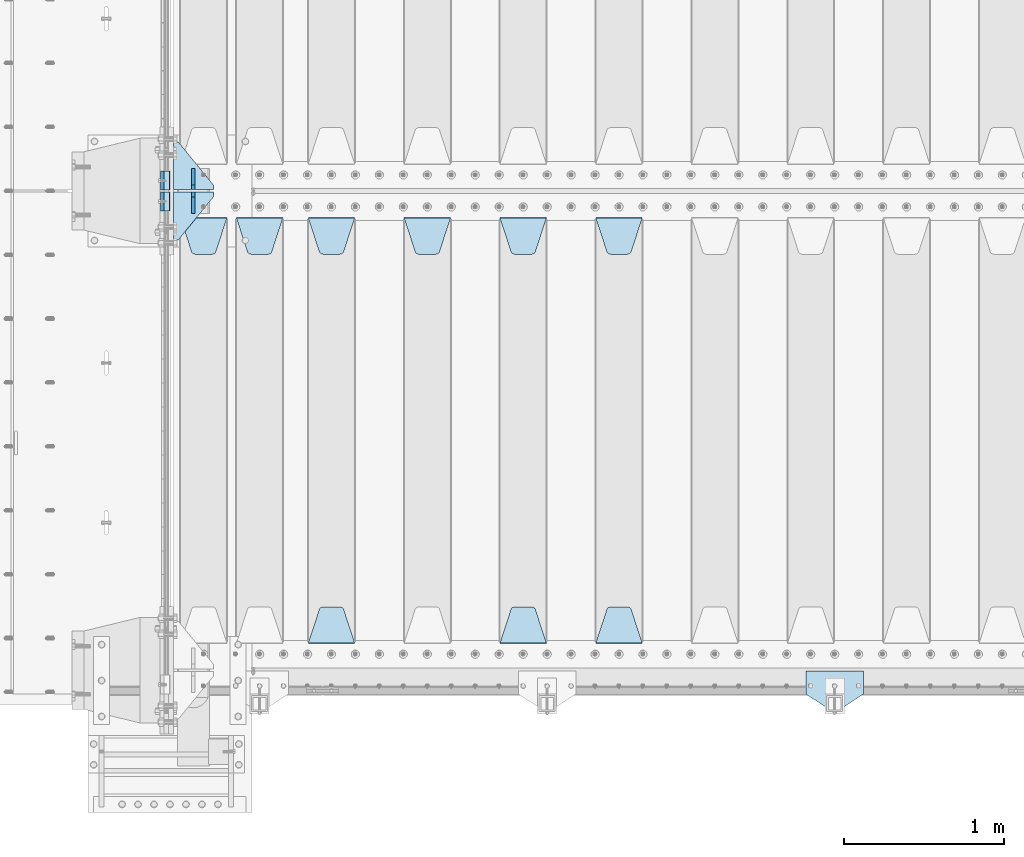
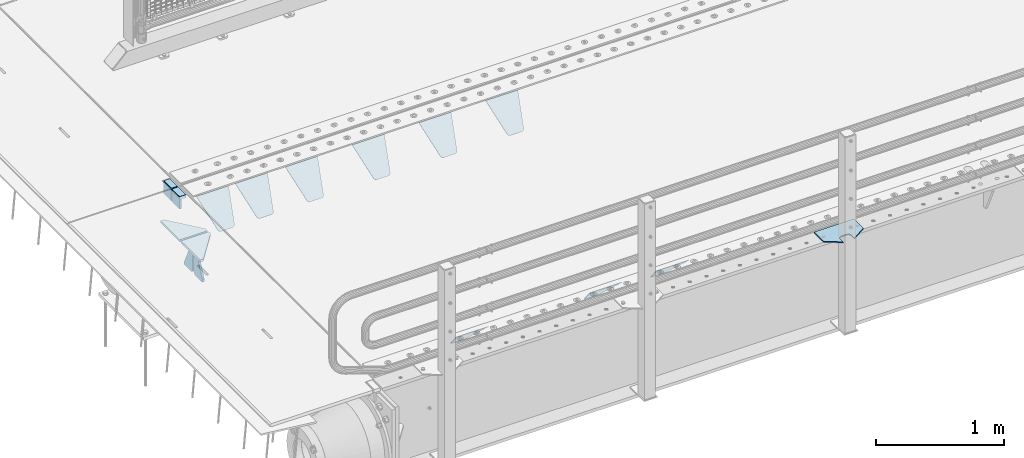
# One storey, part 167 of 208: 18 plates.
"""IFC2X3 building model written with IfcOpenShell, lengths in millimetres."""

import ifcopenshell
import ifcopenshell.guid

model = None  # the IFC model being written
_history = None  # IfcOwnerHistory: only IFC2X3 demands one
_inside = {}  # id of a spatial element -> (the spatial element, [elements in it])
_under = {}  # id of a project, library or spatial element -> (it, [spatial elements below it])
_declared = {}  # id of a project -> (the project, [libraries it declares])
_typed = {}  # id of a type object -> (the type object, [elements of that type])
_made_of = {}  # id of a material, layer set ... -> (it, [elements and type objects made of it])


def new_model(schema):
    """Start an empty IFC model of exactly this schema.

    Asked for "IFC4X3", IfcOpenShell would pick the latest addendum, in which some entities
    have other attributes; the version numbers below select the first issue.
    IFC2X3 requires an IfcOwnerHistory on every rooted entity: one is made here for all.
    """
    global model, _history
    if schema == "IFC4X3":
        model = ifcopenshell.file(schema_version=(4, 3, 0, 0))
    else:
        model = ifcopenshell.file(schema=schema)
    _inside.clear()
    _under.clear()
    _declared.clear()
    _typed.clear()
    _made_of.clear()
    _history = None
    if model.schema == "IFC2X3":
        org = make("IfcOrganization", Name="unknown")
        user = make(
            "IfcPersonAndOrganization",
            ThePerson=make("IfcPerson", FamilyName="unknown"),
            TheOrganization=org,
        )
        app = make(
            "IfcApplication",
            ApplicationDeveloper=org,
            Version="unknown",
            ApplicationFullName="unknown",
            ApplicationIdentifier="unknown",
        )
        _history = make(
            "IfcOwnerHistory",
            OwningUser=user,
            OwningApplication=app,
            ChangeAction="ADDED",
            CreationDate=0,
        )
    return model


def make(cls, **values):
    """One entity of the class cls with the attributes given. An attribute that is None is left unset."""
    return model.create_entity(
        cls, **{name: value for name, value in values.items() if value is not None}
    )


def rooted(cls, **values):
    """An entity with a GlobalId (a new one), such as an element, a storey or a relation."""
    return make(cls, GlobalId=ifcopenshell.guid.new(), OwnerHistory=_history, **values)


def si_unit(unit_type, name, prefix=None):
    """IfcSIUnit, for example si_unit("LENGTHUNIT", "METRE", prefix="MILLI")."""
    return make("IfcSIUnit", UnitType=unit_type, Prefix=prefix, Name=name)


def assignment(units):
    """IfcUnitAssignment: the units of a project."""
    return None if units is None else make("IfcUnitAssignment", Units=units)


def point(xyz):
    """IfcCartesianPoint."""
    return None if xyz is None else make("IfcCartesianPoint", Coordinates=xyz)


def direction(xyz):
    """IfcDirection."""
    return None if xyz is None else make("IfcDirection", DirectionRatios=xyz)


def frame(location, z_axis=None, x_axis=None):
    """IfcAxis2Placement3D, a coordinate frame: its origin and axes. An axis left out is left unset."""
    return make(
        "IfcAxis2Placement3D",
        Location=point(location),
        Axis=direction(z_axis),
        RefDirection=direction(x_axis),
    )


def origin_with_axes():
    """The frame at (0, 0, 0) with the z axis (0, 0, 1) and the x axis (1, 0, 0) written out."""
    return frame((0.0, 0.0, 0.0), z_axis=(0.0, 0.0, 1.0), x_axis=(1.0, 0.0, 0.0))


def place(relative_to, where):
    """IfcLocalPlacement: puts the frame where relative to a parent placement (None: the world)."""
    return make(
        "IfcLocalPlacement", PlacementRelTo=relative_to, RelativePlacement=where
    )


def context(
    kind, dimensions, precision=None, world=None, true_north=None, identifier=None
):
    """IfcGeometricRepresentationContext, for example the 3D "Model" context."""
    return make(
        "IfcGeometricRepresentationContext",
        ContextIdentifier=identifier,
        ContextType=kind,
        CoordinateSpaceDimension=dimensions,
        Precision=precision,
        WorldCoordinateSystem=world,
        TrueNorth=true_north,
    )


def subcontext(parent, identifier, kind, view, scale=None):
    """IfcGeometricRepresentationSubContext, for example "Body" below "Model"."""
    return make(
        "IfcGeometricRepresentationSubContext",
        ContextIdentifier=identifier,
        ContextType=kind,
        ParentContext=parent,
        TargetScale=scale,
        TargetView=view,
    )


def project(units=None, contexts=None):
    """IfcProject with its units and contexts."""
    return rooted(
        "IfcProject",
        Name="project",
        RepresentationContexts=contexts,
        UnitsInContext=assignment(units),
    )


def spatial(cls, under=None, at=None, **own):
    """A site, building, storey or space (cls), placed at a placement, below another one or the project."""
    s = rooted(cls, ObjectPlacement=at, **own)
    if under is not None:
        _under.setdefault(under.id(), (under, []))[1].append(s)
    return s


def faces_of(points, faces, orient=None, outer=None):
    """IfcFace entities. A face is a list of loops; a loop is a list of indices into points, from 0.

    orient and outer hold one flag for each loop. By default every Orientation is true, the
    first loop of a face is its IfcFaceOuterBound and the others are IfcFaceBound.
    """
    made = []
    for i, loops in enumerate(faces):
        bounds = []
        for j, loop in enumerate(loops):
            is_outer = j == 0 if outer is None else outer[i][j]
            bounds.append(
                make(
                    "IfcFaceOuterBound" if is_outer else "IfcFaceBound",
                    Bound=make("IfcPolyLoop", Polygon=[points[k] for k in loop]),
                    Orientation=True if orient is None else orient[i][j],
                )
            )
        made.append(make("IfcFace", Bounds=bounds))
    return made


def faceted_brep(points, faces, orient=None, outer=None, voids=None):
    """IfcFacetedBrep: a solid bounded by flat faces; with voids (closed shells), ...WithVoids."""
    shared = [point(p) for p in points]
    hull = make("IfcClosedShell", CfsFaces=faces_of(shared, faces, orient, outer))
    if voids is None:
        return make("IfcFacetedBrep", Outer=hull)
    return make(
        "IfcFacetedBrepWithVoids",
        Outer=hull,
        Voids=[
            make(cls, CfsFaces=faces_of(shared, fs, o, b)) for cls, fs, o, b in voids
        ],
    )


def shape(context_of_items, identifier, shape_type, items):
    """IfcShapeRepresentation: the items that make up one representation, for example the "Body"."""
    return make(
        "IfcShapeRepresentation",
        ContextOfItems=context_of_items,
        RepresentationIdentifier=identifier,
        RepresentationType=shape_type,
        Items=items,
    )


def material(Name=None, Category=None):
    """IfcMaterial."""
    return make("IfcMaterial", Name=Name, Category=Category)


def made_of(thing, what):
    """Note that an element or type object is made of a material, layer set ...; save() writes the relation."""
    if what is not None:
        _made_of.setdefault(what.id(), (what, []))[1].append(thing)
    return thing


def type_object(cls, material=None, **own):
    """A type object (cls), such as IfcWallType, which elements share."""
    return made_of(rooted(cls, **own), material)


def element(
    cls,
    number,
    at=None,
    inside=None,
    cuts=None,
    type_object=None,
    material=None,
    context=None,
    identifier="Body",
    shape_type=None,
    held_by="IfcProductDefinitionShape",
    body=None,
    shapes=None,
    **own,
):
    """One element of the class cls, such as IfcWall. Its Tag is "e" and its number.

    at: its placement. inside: the storey or other place that contains it. cuts: it is an
    opening in that element (IfcRelVoidsElement). A single representation is given by context,
    identifier, shape_type and body (its items); several are given by shapes. held_by: the class
    of the entity that holds the representations. save() writes the other relations.
    """
    e = rooted(cls, Tag="e%d" % number, ObjectPlacement=at, **own)
    if body is not None:
        shapes = [shape(context, identifier, shape_type, body)]
    if shapes is not None:
        e.Representation = make(held_by, Representations=shapes)
    if inside is not None:
        _inside.setdefault(inside.id(), (inside, []))[1].append(e)
    if cuts is not None:
        rooted(
            "IfcRelVoidsElement", RelatingBuildingElement=cuts, RelatedOpeningElement=e
        )
    if type_object is not None:
        _typed.setdefault(type_object.id(), (type_object, []))[1].append(e)
    return made_of(e, material)


def aggregate(whole, parts):
    """IfcRelAggregates: a whole, such as a stair, and the parts it consists of."""
    return rooted("IfcRelAggregates", RelatingObject=whole, RelatedObjects=parts)


def save(model, path):
    """Write the relations noted so far, then the file.

    IfcRelAggregates (storeys below a building ...), IfcRelContainedInSpatialStructure (elements
    in a storey), IfcRelDefinesByType, IfcRelAssociatesMaterial and IfcRelDeclares: one each for
    every whole, place, type object, material and project.
    """
    for whole, parts in _under.values():
        aggregate(whole, parts)
    for where, things in _inside.values():
        rooted(
            "IfcRelContainedInSpatialStructure",
            RelatedElements=things,
            RelatingStructure=where,
        )
    for kind, things in _typed.values():
        rooted("IfcRelDefinesByType", RelatedObjects=things, RelatingType=kind)
    for what, things in _made_of.values():
        rooted("IfcRelAssociatesMaterial", RelatedObjects=things, RelatingMaterial=what)
    for by, libraries in _declared.values():
        rooted("IfcRelDeclares", RelatingContext=by, RelatedDefinitions=libraries)
    model.write(path)


model = new_model("IFC2X3")

# Units and contexts
model_context = context("Model", 3, precision=1e-05, world=origin_with_axes())
body_context = subcontext(model_context, "Body", "Model", "MODEL_VIEW")
ifc_project = project(units=[si_unit("LENGTHUNIT", "METRE", prefix="MILLI"), si_unit("AREAUNIT", "SQUARE_METRE"), si_unit("VOLUMEUNIT", "CUBIC_METRE"), si_unit("MASSUNIT", "GRAM", prefix="KILO"), si_unit("TIMEUNIT", "SECOND"), si_unit("PLANEANGLEUNIT", "RADIAN"), si_unit("SOLIDANGLEUNIT", "STERADIAN"), si_unit("THERMODYNAMICTEMPERATUREUNIT", "DEGREE_CELSIUS"), si_unit("LUMINOUSINTENSITYUNIT", "LUMEN")], contexts=[model_context])

# Site, building, storey
site_placement = place(None, origin_with_axes())
site = spatial("IfcSite", under=ifc_project, at=site_placement, CompositionType="ELEMENT")
building_placement = place(site_placement, origin_with_axes())
building = spatial("IfcBuilding", under=site, at=building_placement, Name="Standard", CompositionType="ELEMENT")
storey_placement = place(building_placement, origin_with_axes())
storey = spatial("IfcBuildingStorey", under=building, at=storey_placement, Name="Undefined", CompositionType="ELEMENT", Elevation=0.0)

# Plates
ifc_material_1 = material()
plate_type_1 = type_object("IfcPlateType", PredefinedType="NOTDEFINED")
plate_1_placement = place(storey_placement, frame((-42460.0, 2935.00000000002, -16.0000763080445), z_axis=(-1.0, 0.0, 0.0), x_axis=(0.0, 0.0, 1.0)))
element("IfcPlate", 1, at=plate_1_placement, inside=storey, type_object=plate_type_1, material=ifc_material_1, context=body_context, shape_type="Brep", body=[
    faceted_brep([(-1.77635683940025e-15, -60.0, 0.0), (2.49929144047201e-09, -59.9999999999995, 60.0), (2.49929144047201e-09, 60.0000000000005, 60.0), (-1.77635683940025e-15, 60.0, -7.27595761418343e-12), (25.0146748218828, -59.9999999999995, 60.0), (25.0146748218828, 60.0, 60.0), (26.5597449794466, -59.9999999999995, 59.7552873949098), (26.5597449794466, 60.0000000000005, 59.7552873949098), (27.9535758796897, -59.9999999999995, 59.0451032832789), (27.9535758796897, 60.0000000000005, 59.0451032832789), (29.0597323263517, -59.9999999999995, 57.9389640667287), (29.0597323263517, 60.0, 57.9389640667287), (29.7699381491534, -59.9999999999995, 56.5451442289705), (29.7699381491534, 60.0000000000005, 56.5451442289705), (30.0146748212763, -59.9999999999995, 55.0000778834001), (30.0146748212763, 60.0000000000005, 55.0000778834001), (30.0154536553013, -59.9999999999995, 5.00007788340736), (30.0154536553013, 60.0000000000005, 5.00007788340736), (29.7707554908505, -59.9999999999995, 3.45497428546514), (29.7707554908505, 60.0000000000005, 3.45497428546514), (29.0605660948355, -59.9999999999995, 2.06111154406972), (29.0605660948355, 60.0000000000005, 2.06111154406972), (27.9544051209123, -59.9999999999995, 0.954933339693525), (27.9544051209123, 60.0000000000005, 0.954933339693525), (26.5605534420796, -59.9999999999995, 0.244722232011554), (26.5605534420796, 60.0000000000005, 0.244722232011554), (25.0154536559091, -59.9999999999991, 7.27595761418343e-12), (25.0154536559091, 60.0000000000005, 7.27595761418343e-12)], [[[0, 1, 2, 3]], [[1, 4, 5, 2]], [[4, 6, 7, 5]], [[6, 8, 9, 7]], [[8, 10, 11, 9]], [[10, 12, 13, 11]], [[12, 14, 15, 13]], [[14, 16, 17, 15]], [[16, 18, 19, 17]], [[18, 20, 21, 19]], [[20, 22, 23, 21]], [[22, 24, 25, 23]], [[24, 26, 27, 25]], [[26, 0, 3, 27]], [[5, 7, 9, 11, 13, 15, 17, 19, 21, 23, 25, 27, 3, 2]], [[26, 24, 22, 20, 18, 16, 14, 12, 10, 8, 6, 4, 1, 0]]]),
])
plate_2_placement = place(storey_placement, frame((-42460.0000000646, 3065.00000043207, -15.999743219274), z_axis=(-1.0, 0.0, 0.0), x_axis=(0.0, -4.95099999998473e-06, 0.999999999987744)))
element("IfcPlate", 2, at=plate_2_placement, inside=storey, type_object=plate_type_1, material=ifc_material_1, context=body_context, shape_type="Brep", body=[
    faceted_brep([(-1.77635683940025e-15, -60.0, 0.0), (-0.000933120085690575, -60.0, 60.0), (-0.000933120085690575, 60.0, 59.9999999999927), (-1.77635683940025e-15, 60.0, -7.27595761418343e-12), (24.9991450303709, -60.0, 60.0), (24.9991450303709, 60.0, 59.9999999999927), (26.544215218168, -60.0, 59.7552873850873), (26.544215218168, 60.0, 59.75528738508), (27.9380461396139, -60.0, 59.0451032459096), (27.9380461396139, 60.0, 59.0451032459096), (29.0442025908961, -60.0, 57.9389639895744), (29.0442025908961, 60.0, 57.9389639895744), (29.7544083969366, -60.0, 56.5451441080368), (29.7544083969366, 60.0, 56.5451441080295), (29.9991450297669, -60.0, 55.0000777244568), (29.9991450297669, 60.0, 55.0000777244495), (29.999922274335, -60.0, 5.00007772445679), (29.999922274335, 60.0, 5.00007772444951), (29.7552240705896, -60.0, 3.45497416452417), (29.7552240705896, 60.0, 3.45497416452417), (29.0450346578116, -60.0, 2.06111146690819), (29.0450346578116, 60.0, 2.06111146690819), (27.9388736885072, -60.0, 0.954933302316931), (27.9388736885072, 60.0, 0.954933302316931), (26.5450220308766, -60.0, 0.244722222181736), (26.5450220308766, 60.0, 0.244722222181736), (24.9999222749392, -60.0, 0.0), (24.9999222749392, 60.0, -7.27595761418343e-12)], [[[0, 1, 2, 3]], [[1, 4, 5, 2]], [[4, 6, 7, 5]], [[6, 8, 9, 7]], [[8, 10, 11, 9]], [[10, 12, 13, 11]], [[12, 14, 15, 13]], [[14, 16, 17, 15]], [[16, 18, 19, 17]], [[18, 20, 21, 19]], [[20, 22, 23, 21]], [[22, 24, 25, 23]], [[24, 26, 27, 25]], [[26, 0, 3, 27]], [[5, 7, 9, 11, 13, 15, 17, 19, 21, 23, 25, 27, 3, 2]], [[26, 24, 22, 20, 18, 16, 14, 12, 10, 8, 6, 4, 1, 0]]]),
])
ifc_material_2 = material(Name="STEEL/S355N")
plate_type_2 = type_object("IfcPlateType", PredefinedType="NOTDEFINED")
plate_3_placement = place(storey_placement, frame((-42510.0, 2995.00008553451, -105.984410846883), z_axis=(0.0, -1.0, 0.0), x_axis=(0.0, 0.0, 1.0)))
element("IfcPlate", 3, at=plate_3_placement, inside=storey, type_object=plate_type_2, material=ifc_material_2, context=body_context, shape_type="Brep", body=[
    faceted_brep([(0.0, -10.0, 0.0), (5.7072624315424e-07, -10.0, 120.0), (5.7072624315424e-07, 10.0, 120.0), (0.0, 10.0, 0.0), (89.9845046997072, -10.0, 120.0), (89.9845046997072, 10.0, 120.0), (89.9843902587891, -10.0, 6.54836185276508e-11), (89.9843902587891, 10.0, 6.54836185276508e-11)], [[[0, 1, 2, 3]], [[1, 4, 5, 2]], [[4, 6, 7, 5]], [[6, 0, 3, 7]], [[5, 7, 3, 2]], [[6, 4, 1, 0]]]),
])
plate_4_placement = place(storey_placement, frame((-42510.0, 3125.00044598119, -106.000068249326), z_axis=(1.0000003385235e-09, -0.999999999987744, -4.95099999993936e-06), x_axis=(0.0, -4.95099999998473e-06, 0.999999999987744)))
element("IfcPlate", 4, at=plate_4_placement, inside=storey, type_object=plate_type_2, material=ifc_material_2, context=body_context, shape_type="Brep", body=[
    faceted_brep([(0.0, -10.0, 0.0), (5.7072624315424e-07, -10.0, 120.0), (5.7072624315424e-07, 10.0, 120.0), (0.0, 10.0, 0.0), (90.0, -10.0, 120.0), (90.0, 10.0, 120.0), (90.0, -10.0, 1.09139364212751e-11), (90.0, 10.0, 1.09139364212751e-11)], [[[0, 1, 2, 3]], [[1, 4, 5, 2]], [[4, 6, 7, 5]], [[6, 0, 3, 7]], [[5, 7, 3, 2]], [[6, 4, 1, 0]]]),
])
plate_type_3 = type_object("IfcPlateType", PredefinedType="NOTDEFINED")
plate_5_placement = place(storey_placement, frame((-39795.0, 2831.76776695596, -1.76776695296758), z_axis=(0.0, -0.707106781186548, -0.707106781186547), x_axis=(1.0, 0.0, 0.0)))
element("IfcPlate", 5, at=plate_5_placement, inside=storey, type_object=plate_type_3, material=ifc_material_2, context=body_context, shape_type="Brep", body=[
    faceted_brep([(0.0, -2.5, 0.0), (69.345504679477, -2.5, 300.17173142483), (69.345504679477, 2.5, 300.17173142483), (0.0, 2.5, 0.0), (70.9274061199576, -2.5, 304.897442415399), (70.9274061199576, 2.5, 304.8974424154), (73.3818627772307, -2.5, 309.234538108527), (73.3818627772307, 2.5, 309.234538108527), (76.6187032999551, -2.5, 313.023683126103), (76.6187032999551, 2.5, 313.023683126103), (80.5190132704993, -2.5, 316.125672595371), (80.5190132704993, 2.5, 316.125672595371), (84.9395038596849, -2.5, 318.426546230476), (84.9395038596849, 2.50000000000091, 318.426546230476), (89.7177759439219, -2.5, 319.841774983275), (89.7177759439219, 2.50000000000091, 319.841774983275), (94.678286292652, -2.49999999999909, 320.319366455078), (94.678286292652, 2.5, 320.319366455078), (195.321713707348, -2.49999999999909, 320.319366455078), (195.321713707348, 2.5, 320.319366455078), (200.282224056078, -2.5, 319.841774983275), (200.282224056078, 2.5, 319.841774983274), (205.060496140315, -2.5, 318.426546230475), (205.060496140315, 2.5, 318.426546230475), (209.480986729501, -2.5, 316.125672595371), (209.480986729501, 2.50000000000091, 316.125672595371), (213.381296700045, -2.5, 313.023683126102), (213.381296700045, 2.5, 313.023683126102), (216.618137222769, -2.5, 309.234538108526), (216.618137222769, 2.5, 309.234538108527), (219.072593880042, -2.5, 304.897442415399), (219.072593880042, 2.5, 304.897442415399), (220.654495320523, -2.5, 300.17173142483), (220.654495320523, 2.5, 300.17173142483), (290.0, -2.5, 0.0), (290.0, 2.5, 0.0)], [[[0, 1, 2, 3]], [[1, 4, 5, 2]], [[4, 6, 7, 5]], [[6, 8, 9, 7]], [[8, 10, 11, 9]], [[10, 12, 13, 11]], [[12, 14, 15, 13]], [[14, 16, 17, 15]], [[16, 18, 19, 17]], [[18, 20, 21, 19]], [[20, 22, 23, 21]], [[22, 24, 25, 23]], [[24, 26, 27, 25]], [[26, 28, 29, 27]], [[28, 30, 31, 29]], [[30, 32, 33, 31]], [[32, 34, 35, 33]], [[34, 0, 3, 35]], [[5, 7, 9, 11, 13, 15, 17, 19, 21, 23, 25, 27, 29, 31, 33, 35, 3, 2]], [[34, 32, 30, 28, 26, 24, 22, 20, 18, 16, 14, 12, 10, 8, 6, 4, 1, 0]]]),
])
plate_6_placement = place(storey_placement, frame((-39505.0, 168.232233047023, -1.76776695296758), z_axis=(0.0, 0.707106781186547, -0.707106781186548), x_axis=(-1.0, 0.0, 0.0)))
element("IfcPlate", 6, at=plate_6_placement, inside=storey, type_object=plate_type_3, material=ifc_material_2, context=body_context, shape_type="Brep", body=[
    faceted_brep([(0.0, -2.5, 0.0), (69.345504679477, -2.5, 300.17173142483), (69.345504679477, 2.5, 300.17173142483), (0.0, 2.5, 0.0), (70.9274061199576, -2.5, 304.897442415399), (70.9274061199576, 2.5, 304.8974424154), (73.3818627772307, -2.5, 309.234538108527), (73.3818627772307, 2.5, 309.234538108527), (76.6187032999551, -2.5, 313.023683126103), (76.6187032999551, 2.5, 313.023683126103), (80.5190132704993, -2.5, 316.125672595371), (80.5190132704993, 2.5, 316.125672595371), (84.9395038596849, -2.5, 318.426546230476), (84.9395038596849, 2.50000000000091, 318.426546230476), (89.7177759439219, -2.5, 319.841774983275), (89.7177759439219, 2.50000000000091, 319.841774983275), (94.678286292652, -2.49999999999909, 320.319366455078), (94.678286292652, 2.5, 320.319366455078), (195.321713707348, -2.49999999999909, 320.319366455078), (195.321713707348, 2.5, 320.319366455078), (200.282224056078, -2.5, 319.841774983275), (200.282224056078, 2.5, 319.841774983274), (205.060496140315, -2.5, 318.426546230475), (205.060496140315, 2.5, 318.426546230475), (209.480986729501, -2.5, 316.125672595371), (209.480986729501, 2.50000000000091, 316.125672595371), (213.381296700045, -2.5, 313.023683126102), (213.381296700045, 2.5, 313.023683126102), (216.618137222769, -2.5, 309.234538108526), (216.618137222769, 2.5, 309.234538108527), (219.072593880042, -2.5, 304.897442415399), (219.072593880042, 2.5, 304.897442415399), (220.654495320523, -2.5, 300.17173142483), (220.654495320523, 2.5, 300.17173142483), (290.0, -2.5, 0.0), (290.0, 2.5, 0.0)], [[[0, 1, 2, 3]], [[1, 4, 5, 2]], [[4, 6, 7, 5]], [[6, 8, 9, 7]], [[8, 10, 11, 9]], [[10, 12, 13, 11]], [[12, 14, 15, 13]], [[14, 16, 17, 15]], [[16, 18, 19, 17]], [[18, 20, 21, 19]], [[20, 22, 23, 21]], [[22, 24, 25, 23]], [[24, 26, 27, 25]], [[26, 28, 29, 27]], [[28, 30, 31, 29]], [[30, 32, 33, 31]], [[32, 34, 35, 33]], [[34, 0, 3, 35]], [[5, 7, 9, 11, 13, 15, 17, 19, 21, 23, 25, 27, 29, 31, 33, 35, 3, 2]], [[34, 32, 30, 28, 26, 24, 22, 20, 18, 16, 14, 12, 10, 8, 6, 4, 1, 0]]]),
])
plate_7_placement = place(storey_placement, frame((-40395.0, 2831.76776695596, -1.76776695296758), z_axis=(0.0, -0.707106781186548, -0.707106781186547), x_axis=(1.0, 0.0, 0.0)))
element("IfcPlate", 7, at=plate_7_placement, inside=storey, type_object=plate_type_3, material=ifc_material_2, context=body_context, shape_type="Brep", body=[
    faceted_brep([(0.0, -2.5, 0.0), (69.345504679477, -2.5, 300.17173142483), (69.345504679477, 2.5, 300.17173142483), (0.0, 2.5, 0.0), (70.9274061199576, -2.5, 304.897442415399), (70.9274061199576, 2.5, 304.8974424154), (73.3818627772307, -2.5, 309.234538108527), (73.3818627772307, 2.5, 309.234538108527), (76.6187032999551, -2.5, 313.023683126103), (76.6187032999551, 2.5, 313.023683126103), (80.5190132704993, -2.5, 316.125672595371), (80.5190132704993, 2.5, 316.125672595371), (84.9395038596849, -2.5, 318.426546230476), (84.9395038596849, 2.50000000000091, 318.426546230476), (89.7177759439219, -2.5, 319.841774983275), (89.7177759439219, 2.50000000000091, 319.841774983275), (94.678286292652, -2.49999999999909, 320.319366455078), (94.678286292652, 2.5, 320.319366455078), (195.321713707348, -2.49999999999909, 320.319366455078), (195.321713707348, 2.5, 320.319366455078), (200.282224056078, -2.5, 319.841774983275), (200.282224056078, 2.5, 319.841774983274), (205.060496140315, -2.5, 318.426546230475), (205.060496140315, 2.5, 318.426546230475), (209.480986729501, -2.5, 316.125672595371), (209.480986729501, 2.50000000000091, 316.125672595371), (213.381296700045, -2.5, 313.023683126102), (213.381296700045, 2.5, 313.023683126102), (216.618137222769, -2.5, 309.234538108526), (216.618137222769, 2.5, 309.234538108527), (219.072593880042, -2.5, 304.897442415399), (219.072593880042, 2.5, 304.897442415399), (220.654495320523, -2.5, 300.17173142483), (220.654495320523, 2.5, 300.17173142483), (290.0, -2.5, 0.0), (290.0, 2.5, 0.0)], [[[0, 1, 2, 3]], [[1, 4, 5, 2]], [[4, 6, 7, 5]], [[6, 8, 9, 7]], [[8, 10, 11, 9]], [[10, 12, 13, 11]], [[12, 14, 15, 13]], [[14, 16, 17, 15]], [[16, 18, 19, 17]], [[18, 20, 21, 19]], [[20, 22, 23, 21]], [[22, 24, 25, 23]], [[24, 26, 27, 25]], [[26, 28, 29, 27]], [[28, 30, 31, 29]], [[30, 32, 33, 31]], [[32, 34, 35, 33]], [[34, 0, 3, 35]], [[5, 7, 9, 11, 13, 15, 17, 19, 21, 23, 25, 27, 29, 31, 33, 35, 3, 2]], [[34, 32, 30, 28, 26, 24, 22, 20, 18, 16, 14, 12, 10, 8, 6, 4, 1, 0]]]),
])
plate_8_placement = place(storey_placement, frame((-40105.0, 168.232233047023, -1.76776695296758), z_axis=(0.0, 0.707106781186547, -0.707106781186548), x_axis=(-1.0, 0.0, 0.0)))
element("IfcPlate", 8, at=plate_8_placement, inside=storey, type_object=plate_type_3, material=ifc_material_2, context=body_context, shape_type="Brep", body=[
    faceted_brep([(0.0, -2.5, 0.0), (69.345504679477, -2.5, 300.17173142483), (69.345504679477, 2.5, 300.17173142483), (0.0, 2.5, 0.0), (70.9274061199576, -2.5, 304.897442415399), (70.9274061199576, 2.5, 304.8974424154), (73.3818627772307, -2.5, 309.234538108527), (73.3818627772307, 2.5, 309.234538108527), (76.6187032999551, -2.5, 313.023683126103), (76.6187032999551, 2.5, 313.023683126103), (80.5190132704993, -2.5, 316.125672595371), (80.5190132704993, 2.5, 316.125672595371), (84.9395038596849, -2.5, 318.426546230476), (84.9395038596849, 2.50000000000091, 318.426546230476), (89.7177759439219, -2.5, 319.841774983275), (89.7177759439219, 2.50000000000091, 319.841774983275), (94.678286292652, -2.49999999999909, 320.319366455078), (94.678286292652, 2.5, 320.319366455078), (195.321713707348, -2.49999999999909, 320.319366455078), (195.321713707348, 2.5, 320.319366455078), (200.282224056078, -2.5, 319.841774983275), (200.282224056078, 2.5, 319.841774983274), (205.060496140315, -2.5, 318.426546230475), (205.060496140315, 2.5, 318.426546230475), (209.480986729501, -2.5, 316.125672595371), (209.480986729501, 2.50000000000091, 316.125672595371), (213.381296700045, -2.5, 313.023683126102), (213.381296700045, 2.5, 313.023683126102), (216.618137222769, -2.5, 309.234538108526), (216.618137222769, 2.5, 309.234538108527), (219.072593880042, -2.5, 304.897442415399), (219.072593880042, 2.5, 304.897442415399), (220.654495320523, -2.5, 300.17173142483), (220.654495320523, 2.5, 300.17173142483), (290.0, -2.5, 0.0), (290.0, 2.5, 0.0)], [[[0, 1, 2, 3]], [[1, 4, 5, 2]], [[4, 6, 7, 5]], [[6, 8, 9, 7]], [[8, 10, 11, 9]], [[10, 12, 13, 11]], [[12, 14, 15, 13]], [[14, 16, 17, 15]], [[16, 18, 19, 17]], [[18, 20, 21, 19]], [[20, 22, 23, 21]], [[22, 24, 25, 23]], [[24, 26, 27, 25]], [[26, 28, 29, 27]], [[28, 30, 31, 29]], [[30, 32, 33, 31]], [[32, 34, 35, 33]], [[34, 0, 3, 35]], [[5, 7, 9, 11, 13, 15, 17, 19, 21, 23, 25, 27, 29, 31, 33, 35, 3, 2]], [[34, 32, 30, 28, 26, 24, 22, 20, 18, 16, 14, 12, 10, 8, 6, 4, 1, 0]]]),
])
plate_9_placement = place(storey_placement, frame((-40995.0, 2831.76776695596, -1.76776695296758), z_axis=(0.0, -0.707106781186548, -0.707106781186547), x_axis=(1.0, 0.0, 0.0)))
element("IfcPlate", 9, at=plate_9_placement, inside=storey, type_object=plate_type_3, material=ifc_material_2, context=body_context, shape_type="Brep", body=[
    faceted_brep([(0.0, -2.5, 0.0), (69.345504679477, -2.5, 300.17173142483), (69.345504679477, 2.5, 300.17173142483), (0.0, 2.5, 0.0), (70.9274061199576, -2.5, 304.897442415399), (70.9274061199576, 2.5, 304.8974424154), (73.3818627772307, -2.5, 309.234538108527), (73.3818627772307, 2.5, 309.234538108527), (76.6187032999551, -2.5, 313.023683126103), (76.6187032999551, 2.5, 313.023683126103), (80.5190132704993, -2.5, 316.125672595371), (80.5190132704993, 2.5, 316.125672595371), (84.9395038596849, -2.5, 318.426546230476), (84.9395038596849, 2.50000000000091, 318.426546230476), (89.7177759439219, -2.5, 319.841774983275), (89.7177759439219, 2.50000000000091, 319.841774983275), (94.678286292652, -2.49999999999909, 320.319366455078), (94.678286292652, 2.5, 320.319366455078), (195.321713707348, -2.49999999999909, 320.319366455078), (195.321713707348, 2.5, 320.319366455078), (200.282224056078, -2.5, 319.841774983275), (200.282224056078, 2.5, 319.841774983274), (205.060496140315, -2.5, 318.426546230475), (205.060496140315, 2.5, 318.426546230475), (209.480986729501, -2.5, 316.125672595371), (209.480986729501, 2.50000000000091, 316.125672595371), (213.381296700045, -2.5, 313.023683126102), (213.381296700045, 2.5, 313.023683126102), (216.618137222769, -2.5, 309.234538108526), (216.618137222769, 2.5, 309.234538108527), (219.072593880042, -2.5, 304.897442415399), (219.072593880042, 2.5, 304.897442415399), (220.654495320523, -2.5, 300.17173142483), (220.654495320523, 2.5, 300.17173142483), (290.0, -2.5, 0.0), (290.0, 2.5, 0.0)], [[[0, 1, 2, 3]], [[1, 4, 5, 2]], [[4, 6, 7, 5]], [[6, 8, 9, 7]], [[8, 10, 11, 9]], [[10, 12, 13, 11]], [[12, 14, 15, 13]], [[14, 16, 17, 15]], [[16, 18, 19, 17]], [[18, 20, 21, 19]], [[20, 22, 23, 21]], [[22, 24, 25, 23]], [[24, 26, 27, 25]], [[26, 28, 29, 27]], [[28, 30, 31, 29]], [[30, 32, 33, 31]], [[32, 34, 35, 33]], [[34, 0, 3, 35]], [[5, 7, 9, 11, 13, 15, 17, 19, 21, 23, 25, 27, 29, 31, 33, 35, 3, 2]], [[34, 32, 30, 28, 26, 24, 22, 20, 18, 16, 14, 12, 10, 8, 6, 4, 1, 0]]]),
])
plate_10_placement = place(storey_placement, frame((-41595.0, 2831.76776695596, -1.76776695296758), z_axis=(0.0, -0.707106781186548, -0.707106781186547), x_axis=(1.0, 0.0, 0.0)))
element("IfcPlate", 10, at=plate_10_placement, inside=storey, type_object=plate_type_3, material=ifc_material_2, context=body_context, shape_type="Brep", body=[
    faceted_brep([(0.0, -2.5, 0.0), (69.345504679477, -2.5, 300.17173142483), (69.345504679477, 2.5, 300.17173142483), (0.0, 2.5, 0.0), (70.9274061199576, -2.5, 304.897442415399), (70.9274061199576, 2.5, 304.8974424154), (73.3818627772307, -2.5, 309.234538108527), (73.3818627772307, 2.5, 309.234538108527), (76.6187032999551, -2.5, 313.023683126103), (76.6187032999551, 2.5, 313.023683126103), (80.5190132704993, -2.5, 316.125672595371), (80.5190132704993, 2.5, 316.125672595371), (84.9395038596849, -2.5, 318.426546230476), (84.9395038596849, 2.50000000000091, 318.426546230476), (89.7177759439219, -2.5, 319.841774983275), (89.7177759439219, 2.50000000000091, 319.841774983275), (94.678286292652, -2.49999999999909, 320.319366455078), (94.678286292652, 2.5, 320.319366455078), (195.321713707348, -2.49999999999909, 320.319366455078), (195.321713707348, 2.5, 320.319366455078), (200.282224056078, -2.5, 319.841774983275), (200.282224056078, 2.5, 319.841774983274), (205.060496140315, -2.5, 318.426546230475), (205.060496140315, 2.5, 318.426546230475), (209.480986729501, -2.5, 316.125672595371), (209.480986729501, 2.50000000000091, 316.125672595371), (213.381296700045, -2.5, 313.023683126102), (213.381296700045, 2.5, 313.023683126102), (216.618137222769, -2.5, 309.234538108526), (216.618137222769, 2.5, 309.234538108527), (219.072593880042, -2.5, 304.897442415399), (219.072593880042, 2.5, 304.897442415399), (220.654495320523, -2.5, 300.17173142483), (220.654495320523, 2.5, 300.17173142483), (290.0, -2.5, 0.0), (290.0, 2.5, 0.0)], [[[0, 1, 2, 3]], [[1, 4, 5, 2]], [[4, 6, 7, 5]], [[6, 8, 9, 7]], [[8, 10, 11, 9]], [[10, 12, 13, 11]], [[12, 14, 15, 13]], [[14, 16, 17, 15]], [[16, 18, 19, 17]], [[18, 20, 21, 19]], [[20, 22, 23, 21]], [[22, 24, 25, 23]], [[24, 26, 27, 25]], [[26, 28, 29, 27]], [[28, 30, 31, 29]], [[30, 32, 33, 31]], [[32, 34, 35, 33]], [[34, 0, 3, 35]], [[5, 7, 9, 11, 13, 15, 17, 19, 21, 23, 25, 27, 29, 31, 33, 35, 3, 2]], [[34, 32, 30, 28, 26, 24, 22, 20, 18, 16, 14, 12, 10, 8, 6, 4, 1, 0]]]),
])
plate_11_placement = place(storey_placement, frame((-41305.0, 168.232233047023, -1.76776695296758), z_axis=(0.0, 0.707106781186547, -0.707106781186548), x_axis=(-1.0, 0.0, 0.0)))
element("IfcPlate", 11, at=plate_11_placement, inside=storey, type_object=plate_type_3, material=ifc_material_2, context=body_context, shape_type="Brep", body=[
    faceted_brep([(0.0, -2.5, 0.0), (69.345504679477, -2.5, 300.17173142483), (69.345504679477, 2.5, 300.17173142483), (0.0, 2.5, 0.0), (70.9274061199576, -2.5, 304.897442415399), (70.9274061199576, 2.5, 304.8974424154), (73.3818627772307, -2.5, 309.234538108527), (73.3818627772307, 2.5, 309.234538108527), (76.6187032999551, -2.5, 313.023683126103), (76.6187032999551, 2.5, 313.023683126103), (80.5190132704993, -2.5, 316.125672595371), (80.5190132704993, 2.5, 316.125672595371), (84.9395038596849, -2.5, 318.426546230476), (84.9395038596849, 2.50000000000091, 318.426546230476), (89.7177759439219, -2.5, 319.841774983275), (89.7177759439219, 2.50000000000091, 319.841774983275), (94.678286292652, -2.49999999999909, 320.319366455078), (94.678286292652, 2.5, 320.319366455078), (195.321713707348, -2.49999999999909, 320.319366455078), (195.321713707348, 2.5, 320.319366455078), (200.282224056078, -2.5, 319.841774983275), (200.282224056078, 2.5, 319.841774983274), (205.060496140315, -2.5, 318.426546230475), (205.060496140315, 2.5, 318.426546230475), (209.480986729501, -2.5, 316.125672595371), (209.480986729501, 2.50000000000091, 316.125672595371), (213.381296700045, -2.5, 313.023683126102), (213.381296700045, 2.5, 313.023683126102), (216.618137222769, -2.5, 309.234538108526), (216.618137222769, 2.5, 309.234538108527), (219.072593880042, -2.5, 304.897442415399), (219.072593880042, 2.5, 304.897442415399), (220.654495320523, -2.5, 300.17173142483), (220.654495320523, 2.5, 300.17173142483), (290.0, -2.5, 0.0), (290.0, 2.5, 0.0)], [[[0, 1, 2, 3]], [[1, 4, 5, 2]], [[4, 6, 7, 5]], [[6, 8, 9, 7]], [[8, 10, 11, 9]], [[10, 12, 13, 11]], [[12, 14, 15, 13]], [[14, 16, 17, 15]], [[16, 18, 19, 17]], [[18, 20, 21, 19]], [[20, 22, 23, 21]], [[22, 24, 25, 23]], [[24, 26, 27, 25]], [[26, 28, 29, 27]], [[28, 30, 31, 29]], [[30, 32, 33, 31]], [[32, 34, 35, 33]], [[34, 0, 3, 35]], [[5, 7, 9, 11, 13, 15, 17, 19, 21, 23, 25, 27, 29, 31, 33, 35, 3, 2]], [[34, 32, 30, 28, 26, 24, 22, 20, 18, 16, 14, 12, 10, 8, 6, 4, 1, 0]]]),
])
plate_12_placement = place(storey_placement, frame((-42045.0, 2831.76776695596, -1.76776695296758), z_axis=(0.0, -0.707106781186548, -0.707106781186547), x_axis=(1.0, 0.0, 0.0)))
element("IfcPlate", 12, at=plate_12_placement, inside=storey, type_object=plate_type_3, material=ifc_material_2, context=body_context, shape_type="Brep", body=[
    faceted_brep([(0.0, -2.5, 0.0), (69.345504679477, -2.5, 300.17173142483), (69.345504679477, 2.5, 300.17173142483), (0.0, 2.5, 0.0), (70.9274061199576, -2.5, 304.897442415399), (70.9274061199576, 2.5, 304.8974424154), (73.3818627772307, -2.5, 309.234538108527), (73.3818627772307, 2.5, 309.234538108527), (76.6187032999551, -2.5, 313.023683126103), (76.6187032999551, 2.5, 313.023683126103), (80.5190132704993, -2.5, 316.125672595371), (80.5190132704993, 2.5, 316.125672595371), (84.9395038596849, -2.5, 318.426546230476), (84.9395038596849, 2.50000000000091, 318.426546230476), (89.7177759439219, -2.5, 319.841774983275), (89.7177759439219, 2.50000000000091, 319.841774983275), (94.678286292652, -2.49999999999909, 320.319366455078), (94.678286292652, 2.5, 320.319366455078), (195.321713707348, -2.49999999999909, 320.319366455078), (195.321713707348, 2.5, 320.319366455078), (200.282224056078, -2.5, 319.841774983275), (200.282224056078, 2.5, 319.841774983274), (205.060496140315, -2.5, 318.426546230475), (205.060496140315, 2.5, 318.426546230475), (209.480986729501, -2.5, 316.125672595371), (209.480986729501, 2.50000000000091, 316.125672595371), (213.381296700045, -2.5, 313.023683126102), (213.381296700045, 2.5, 313.023683126102), (216.618137222769, -2.5, 309.234538108526), (216.618137222769, 2.5, 309.234538108527), (219.072593880042, -2.5, 304.897442415399), (219.072593880042, 2.5, 304.897442415399), (220.654495320523, -2.5, 300.17173142483), (220.654495320523, 2.5, 300.17173142483), (290.0, -2.5, 0.0), (290.0, 2.5, 0.0)], [[[0, 1, 2, 3]], [[1, 4, 5, 2]], [[4, 6, 7, 5]], [[6, 8, 9, 7]], [[8, 10, 11, 9]], [[10, 12, 13, 11]], [[12, 14, 15, 13]], [[14, 16, 17, 15]], [[16, 18, 19, 17]], [[18, 20, 21, 19]], [[20, 22, 23, 21]], [[22, 24, 25, 23]], [[24, 26, 27, 25]], [[26, 28, 29, 27]], [[28, 30, 31, 29]], [[30, 32, 33, 31]], [[32, 34, 35, 33]], [[34, 0, 3, 35]], [[5, 7, 9, 11, 13, 15, 17, 19, 21, 23, 25, 27, 29, 31, 33, 35, 3, 2]], [[34, 32, 30, 28, 26, 24, 22, 20, 18, 16, 14, 12, 10, 8, 6, 4, 1, 0]]]),
])
plate_13_placement = place(storey_placement, frame((-42395.0, 2831.76776695596, -1.76776695296758), z_axis=(0.0, -0.707106781186548, -0.707106781186547), x_axis=(1.0, 0.0, 0.0)))
element("IfcPlate", 13, at=plate_13_placement, inside=storey, type_object=plate_type_3, material=ifc_material_2, context=body_context, shape_type="Brep", body=[
    faceted_brep([(0.0, -2.5, 0.0), (69.345504679477, -2.5, 300.17173142483), (69.345504679477, 2.5, 300.17173142483), (0.0, 2.5, 0.0), (70.9274061199576, -2.5, 304.897442415399), (70.9274061199576, 2.5, 304.8974424154), (73.3818627772307, -2.5, 309.234538108527), (73.3818627772307, 2.5, 309.234538108527), (76.6187032999551, -2.5, 313.023683126103), (76.6187032999551, 2.5, 313.023683126103), (80.5190132704993, -2.5, 316.125672595371), (80.5190132704993, 2.5, 316.125672595371), (84.9395038596849, -2.5, 318.426546230476), (84.9395038596849, 2.50000000000091, 318.426546230476), (89.7177759439219, -2.5, 319.841774983275), (89.7177759439219, 2.50000000000091, 319.841774983275), (94.678286292652, -2.49999999999909, 320.319366455078), (94.678286292652, 2.5, 320.319366455078), (195.321713707348, -2.49999999999909, 320.319366455078), (195.321713707348, 2.5, 320.319366455078), (200.282224056078, -2.5, 319.841774983275), (200.282224056078, 2.5, 319.841774983274), (205.060496140315, -2.5, 318.426546230475), (205.060496140315, 2.5, 318.426546230475), (209.480986729501, -2.5, 316.125672595371), (209.480986729501, 2.50000000000091, 316.125672595371), (213.381296700045, -2.5, 313.023683126102), (213.381296700045, 2.5, 313.023683126102), (216.618137222769, -2.5, 309.234538108526), (216.618137222769, 2.5, 309.234538108527), (219.072593880042, -2.5, 304.897442415399), (219.072593880042, 2.5, 304.897442415399), (220.654495320523, -2.5, 300.17173142483), (220.654495320523, 2.5, 300.17173142483), (290.0, -2.5, 0.0), (290.0, 2.5, 0.0)], [[[0, 1, 2, 3]], [[1, 4, 5, 2]], [[4, 6, 7, 5]], [[6, 8, 9, 7]], [[8, 10, 11, 9]], [[10, 12, 13, 11]], [[12, 14, 15, 13]], [[14, 16, 17, 15]], [[16, 18, 19, 17]], [[18, 20, 21, 19]], [[20, 22, 23, 21]], [[22, 24, 25, 23]], [[24, 26, 27, 25]], [[26, 28, 29, 27]], [[28, 30, 31, 29]], [[30, 32, 33, 31]], [[32, 34, 35, 33]], [[34, 0, 3, 35]], [[5, 7, 9, 11, 13, 15, 17, 19, 21, 23, 25, 27, 29, 31, 33, 35, 3, 2]], [[34, 32, 30, 28, 26, 24, 22, 20, 18, 16, 14, 12, 10, 8, 6, 4, 1, 0]]]),
])
plate_type_4 = type_object("IfcPlateType", PredefinedType="NOTDEFINED")
for number, where, z_axis, x_axis in (
    (14, (-42190.0, 3008.0, -515.0), (0.0, 1.0, 0.0), (-1.0, 0.0, 0.0)),
    (15, (-42190.0, 2992.0, -515.0), (0.0, -1.0, 0.0), (-1.0, 0.0, 0.0)),
):
    element("IfcPlate", number, at=place(storey_placement, frame(where, z_axis=z_axis, x_axis=x_axis)), inside=storey, type_object=plate_type_4, material=ifc_material_2, context=body_context, shape_type="Brep", body=[
        faceted_brep([(0.0, -10.0, 0.0), (0.0, -10.0, 30.0), (0.0, 10.0, 30.0), (0.0, 10.0, 0.0), (220.0, -10.0, 300.0), (220.0, 10.0, 300.0), (250.0, -10.0, 300.0), (250.0, 10.0, 300.0), (250.0, -10.0, 0.0), (250.0, 10.0, 0.0)], [[[0, 1, 2, 3]], [[1, 4, 5, 2]], [[4, 6, 7, 5]], [[6, 8, 9, 7]], [[8, 0, 3, 9]], [[5, 7, 9, 3, 2]], [[8, 6, 4, 1, 0]]]),
    ])
plate_type_5 = type_object("IfcPlateType", PredefinedType="NOTDEFINED")
for number, where, z_axis, x_axis in (
    (16, (-42315.0, 3140.0, -860.0), (0.0, 0.0, 1.0), (0.0, -1.0, 0.0)),
    (17, (-42315.0, 2860.0, -860.0), (0.0, 0.0, 1.0), (0.0, 1.0, 0.0)),
):
    element("IfcPlate", number, at=place(storey_placement, frame(where, z_axis=z_axis, x_axis=x_axis)), inside=storey, type_object=plate_type_5, material=ifc_material_2, context=body_context, shape_type="Brep", body=[
        faceted_brep([(0.0, -10.0, 0.0), (0.0, -10.0, 30.0), (0.0, 10.0, 30.0), (0.0, 10.0, 0.0), (102.0, -10.0, 250.0), (102.0, 10.0, 250.0), (132.0, -10.0, 250.0), (132.0, 10.0, 250.0), (132.0, -10.0, 30.0), (132.0, 10.0, 30.0), (131.544232590366, -10.0, 24.790554669992), (131.544232590366, 10.0, 24.790554669992), (130.190778623577, -10.0, 19.7393957002299), (130.190778623577, 10.0, 19.7393957002299), (127.980762113533, -10.0, 15.0), (127.980762113533, 10.0, 15.0), (124.981333293569, -10.0, 10.7163717094038), (124.981333293569, 10.0, 10.7163717094038), (121.283628290596, -10.0, 7.01866670643062), (121.283628290596, 10.0, 7.01866670643062), (117.0, -10.0, 4.01923788646684), (117.0, 10.0, 4.01923788646684), (112.26060429977, -10.0, 1.80922137642278), (112.26060429977, 10.0, 1.80922137642278), (107.209445330008, -10.0, 0.455767409633722), (107.209445330008, 10.0, 0.455767409633722), (102.0, -10.0, 0.0), (102.0, 10.0, 0.0)], [[[0, 1, 2, 3]], [[1, 4, 5, 2]], [[4, 6, 7, 5]], [[6, 8, 9, 7]], [[8, 10, 11, 9]], [[10, 12, 13, 11]], [[12, 14, 15, 13]], [[14, 16, 17, 15]], [[16, 18, 19, 17]], [[18, 20, 21, 19]], [[20, 22, 23, 21]], [[22, 24, 25, 23]], [[24, 26, 27, 25]], [[26, 0, 3, 27]], [[5, 7, 9, 11, 13, 15, 17, 19, 21, 23, 25, 27, 3, 2]], [[26, 24, 22, 20, 18, 16, 14, 12, 10, 8, 6, 4, 1, 0]]]),
    ])
ifc_material_3 = material(Name="STEEL/S355J2")
plate_type_6 = type_object("IfcPlateType", PredefinedType="NOTDEFINED")
plate_14_placement = place(storey_placement, frame((-38120.0, -4.99999999999636, 5.00000000004911), z_axis=(0.0, -1.0, 0.0), x_axis=(-1.0, 0.0, 0.0)))
element("IfcPlate", 18, at=plate_14_placement, inside=storey, type_object=plate_type_6, material=ifc_material_3, context=body_context, shape_type="Brep", body=[
    faceted_brep([(0.0, -5.0, 0.0), (2.31396552408114e-06, -5.0, 145.0), (2.31396552408114e-06, 5.0, 145.0), (0.0, 5.0, 0.0), (130.0, -5.0, 230.0), (130.0, 5.0, 230.0), (130.0, -5.0, 180.0), (130.0, 5.0, 180.0), (130.48036798992, -5.0, 175.122741949597), (130.48036798992, 5.0, 175.122741949597), (131.903011687216, -5.0, 170.432914190873), (131.903011687216, 5.0, 170.432914190873), (134.213259692435, -5.0, 166.11074417451), (134.213259692435, 5.0, 166.11074417451), (137.322330470335, -5.0, 162.322330470336), (137.322330470335, 5.0, 162.322330470336), (141.110744174512, -5.0, 159.213259692437), (141.110744174512, 5.0, 159.213259692437), (145.432914190871, -5.0, 156.903011687218), (145.432914190871, 5.0, 156.903011687218), (150.122741949595, -5.0, 155.48036798992), (150.122741949595, 5.0, 155.48036798992), (155.0, -5.0, 155.0), (155.0, 5.0, 155.0), (205.0, -5.0, 155.0), (205.0, 5.0, 155.0), (209.877258050405, -5.0, 155.48036798992), (209.877258050405, 5.0, 155.48036798992), (214.567085809129, -5.0, 156.903011687218), (214.567085809129, 5.0, 156.903011687218), (218.889255825488, -5.0, 159.213259692437), (218.889255825488, 5.0, 159.213259692437), (222.677669529665, -5.0, 162.322330470336), (222.677669529665, 5.0, 162.322330470336), (225.786740307565, -5.0, 166.11074417451), (225.786740307565, 5.0, 166.11074417451), (228.096988312784, -5.0, 170.432914190873), (228.096988312784, 5.0, 170.432914190873), (229.51963201008, -5.0, 175.122741949597), (229.51963201008, 5.0, 175.122741949597), (230.0, -5.0, 180.0), (230.0, 5.0, 180.0), (230.0, -5.0, 230.0), (230.0, 5.0, 230.0), (360.0, -5.0, 145.0), (360.0, 5.0, 145.0), (360.0, -5.0, -7.27595761418343e-12), (360.0, 5.0, -7.27595761418343e-12)], [[[0, 1, 2, 3]], [[1, 4, 5, 2]], [[4, 6, 7, 5]], [[6, 8, 9, 7]], [[8, 10, 11, 9]], [[10, 12, 13, 11]], [[12, 14, 15, 13]], [[14, 16, 17, 15]], [[16, 18, 19, 17]], [[18, 20, 21, 19]], [[20, 22, 23, 21]], [[22, 24, 25, 23]], [[24, 26, 27, 25]], [[26, 28, 29, 27]], [[28, 30, 31, 29]], [[30, 32, 33, 31]], [[32, 34, 35, 33]], [[34, 36, 37, 35]], [[36, 38, 39, 37]], [[38, 40, 41, 39]], [[40, 42, 43, 41]], [[42, 44, 45, 43]], [[44, 46, 47, 45]], [[46, 0, 3, 47]], [[5, 7, 9, 11, 13, 15, 17, 19, 21, 23, 25, 27, 29, 31, 33, 35, 37, 39, 41, 43, 45, 47, 3, 2]], [[46, 44, 42, 40, 38, 36, 34, 32, 30, 28, 26, 24, 22, 20, 18, 16, 14, 12, 10, 8, 6, 4, 1, 0]]]),
])

save(model, "model.ifc")
